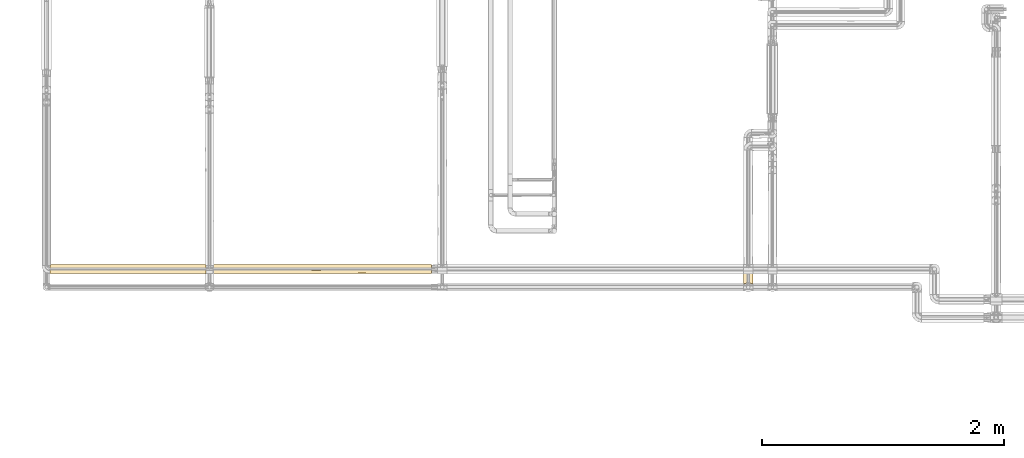
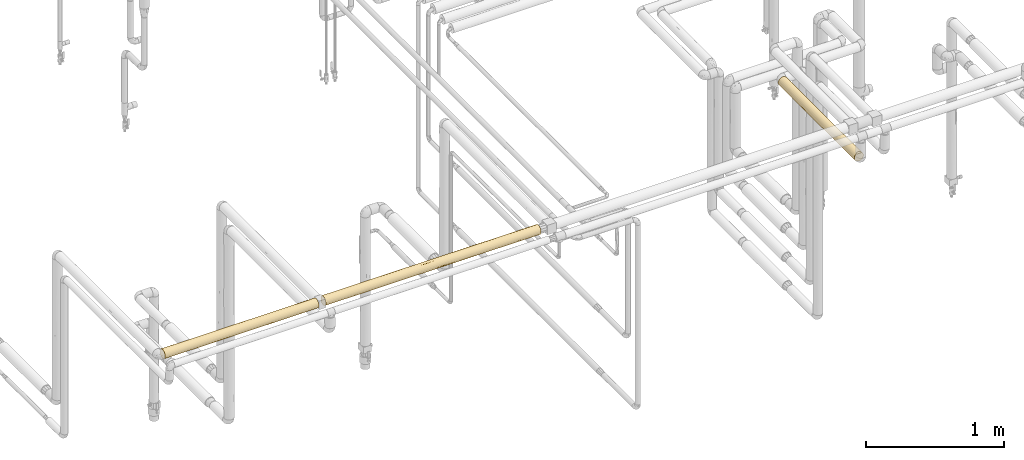
# One storey, part 22 of 827: 3 coverings.
"""IFC2X3 building model written with IfcOpenShell, lengths in millimetres."""

from ifc_helpers import new_model, entity, si_unit, converted_unit, derived_unit, direction, frame, origin, place, context, subcontext, project, spatial, faceted_brep, element, save


model = new_model("IFC2X3")

# Units and contexts
model_context = context("Model", 3, precision=0.01, world=origin(), true_north=direction((6.12303176911189e-17, 1.0)))
body_context = subcontext(model_context, "Body", "Model", "MODEL_VIEW")
ifc_project = project(units=[si_unit("LENGTHUNIT", "METRE", prefix="MILLI"), si_unit("AREAUNIT", "SQUARE_METRE"), si_unit("VOLUMEUNIT", "CUBIC_METRE"), converted_unit("PLANEANGLEUNIT", "DEGREE", entity("IfcRatioMeasure", 0.0174532925199433), si_unit("PLANEANGLEUNIT", "RADIAN"), dimensions=[0, 0, 0, 0, 0, 0, 0]), si_unit("MASSUNIT", "GRAM", prefix="KILO"), derived_unit("MASSDENSITYUNIT", [(si_unit("MASSUNIT", "GRAM", prefix="KILO"), 1), (si_unit("LENGTHUNIT", "METRE"), -3)]), derived_unit("MOMENTOFINERTIAUNIT", [(si_unit("LENGTHUNIT", "METRE"), 4)]), si_unit("TIMEUNIT", "SECOND"), si_unit("FREQUENCYUNIT", "HERTZ"), si_unit("THERMODYNAMICTEMPERATUREUNIT", "DEGREE_CELSIUS"), derived_unit("THERMALTRANSMITTANCEUNIT", [(si_unit("MASSUNIT", "GRAM", prefix="KILO"), 1), (si_unit("THERMODYNAMICTEMPERATUREUNIT", "KELVIN"), -1), (si_unit("TIMEUNIT", "SECOND"), -3)]), derived_unit("VOLUMETRICFLOWRATEUNIT", [(si_unit("LENGTHUNIT", "METRE"), 3), (si_unit("TIMEUNIT", "SECOND"), -1)]), derived_unit("MASSFLOWRATEUNIT", [(si_unit("MASSUNIT", "GRAM", prefix="KILO"), 1), (si_unit("TIMEUNIT", "SECOND"), -1)]), derived_unit("ROTATIONALFREQUENCYUNIT", [(si_unit("TIMEUNIT", "SECOND"), -1)]), si_unit("ELECTRICCURRENTUNIT", "AMPERE"), si_unit("ELECTRICVOLTAGEUNIT", "VOLT"), si_unit("POWERUNIT", "WATT"), si_unit("FORCEUNIT", "NEWTON", prefix="KILO"), si_unit("ILLUMINANCEUNIT", "LUX"), si_unit("LUMINOUSFLUXUNIT", "LUMEN"), si_unit("LUMINOUSINTENSITYUNIT", "CANDELA"), derived_unit("USERDEFINED", [(si_unit("MASSUNIT", "GRAM", prefix="KILO"), -1), (si_unit("LENGTHUNIT", "METRE"), -2), (si_unit("TIMEUNIT", "SECOND"), 3), (si_unit("LUMINOUSFLUXUNIT", "LUMEN"), 1)]), derived_unit("LINEARVELOCITYUNIT", [(si_unit("LENGTHUNIT", "METRE"), 1), (si_unit("TIMEUNIT", "SECOND"), -1)]), si_unit("PRESSUREUNIT", "PASCAL"), derived_unit("USERDEFINED", [(si_unit("LENGTHUNIT", "METRE"), -2), (si_unit("MASSUNIT", "GRAM", prefix="KILO"), 1), (si_unit("TIMEUNIT", "SECOND"), -2)]), derived_unit("LINEARFORCEUNIT", [(si_unit("MASSUNIT", "GRAM", prefix="KILO"), 1), (si_unit("LENGTHUNIT", "METRE"), 1), (si_unit("TIMEUNIT", "SECOND"), -2), (si_unit("LENGTHUNIT", "METRE"), -1)]), derived_unit("PLANARFORCEUNIT", [(si_unit("MASSUNIT", "GRAM", prefix="KILO"), 1), (si_unit("LENGTHUNIT", "METRE"), 1), (si_unit("TIMEUNIT", "SECOND"), -2), (si_unit("LENGTHUNIT", "METRE"), -2)])], contexts=[model_context])

# Site, building, storey
site_placement = place(None, origin())
site = spatial("IfcSite", under=ifc_project, at=site_placement, CompositionType="ELEMENT")
building_placement = place(site_placement, origin())
building = spatial("IfcBuilding", under=site, at=building_placement, CompositionType="ELEMENT")
storey_placement = place(building_placement, frame((0.0, 0.0, 28200.0)))
storey = spatial("IfcBuildingStorey", under=building, at=storey_placement, Name="08", CompositionType="ELEMENT", Elevation=28200.0)

# Coverings
covering_1_placement = place(storey_placement, frame((11959.41, 9702.8, 2810.01)))
element("IfcCovering", 1, at=covering_1_placement, inside=storey, Name=":ADSK_", ObjectType=":ADSK_", PredefinedType="INSULATION", context=body_context, shape_type="Brep", body=[
    faceted_brep([(1.6, 6.74, 20.8), (1.6, 2.9, 30.06), (1.6, 1.6, 40.0), (1.6, 2.9, 49.93), (1.6, 6.74, 59.2), (1.6, 12.84, 67.15), (1.6, 20.8, 73.25), (1.6, 30.06, 77.09), (1.6, 40.0, 78.4), (1.6, 48.2, 77.51), (1.6, 56.01, 74.9), (1.6, 63.08, 70.68), (1.6, 69.1, 65.05), (1.6, 69.1, 14.94), (1.6, 63.08, 9.31), (1.6, 56.01, 5.09), (1.6, 48.2, 2.48), (1.6, 40.0, 1.6), (1.6, 30.06, 2.9), (1.6, 20.8, 6.74), (1.6, 12.84, 12.84), (1290.39, 1.6, 40.0), (1290.39, 2.9, 30.06), (1290.39, 6.74, 20.8), (1290.39, 12.84, 12.84), (1290.39, 20.8, 6.74), (1290.39, 30.06, 2.9), (1290.39, 40.0, 1.6), (1290.39, 48.16, 2.47), (1290.39, 55.94, 5.06), (1290.39, 62.99, 9.24), (1290.39, 69.0, 14.82), (1290.39, 69.0, 65.17), (1290.39, 62.99, 70.75), (1290.39, 55.94, 74.93), (1290.39, 48.16, 77.52), (1290.39, 40.0, 78.4), (1290.39, 30.06, 77.09), (1290.39, 20.8, 73.25), (1290.39, 12.84, 67.15), (1290.39, 6.74, 59.2), (1290.39, 2.9, 49.93), (1281.6, 77.78, 33.17), (1283.41, 75.97, 26.56), (970.5, 77.48, 31.67), (1072.02, 59.58, 6.96), (1013.88, 52.12, 3.56), (1013.87, 66.14, 11.87), (256.38, 52.17, 3.58), (213.25, 40.0, 1.6), (186.53, 59.66, 7.01), (1286.38, 73.01, 20.38), (940.16, 74.55, 23.24), (1093.87, 71.05, 17.4), (877.22, 70.5, 16.67), (1064.62, 78.4, 40.0), (876.39, 78.4, 40.0), (828.29, 59.58, 6.96), (647.31, 76.53, 28.17), (353.03, 74.59, 23.33), (335.45, 77.52, 31.84), (227.27, 78.4, 40.0), (443.64, 78.4, 40.0), (5.57, 73.07, 20.48), (387.82, 70.53, 16.71), (506.99, 66.03, 11.77), (406.4, 59.66, 7.01), (256.39, 66.24, 11.96), (605.06, 50.39, 3.03), (857.64, 40.0, 1.6), (650.71, 40.0, 1.6), (641.27, 40.0, 1.6), (434.34, 40.0, 1.6), (424.9, 40.0, 1.6), (8.5, 76.0, 26.63), (10.29, 77.79, 33.21), (617.64, 60.96, 7.83), (745.51, 65.81, 11.57), (646.28, 70.86, 17.15), (1074.02, 40.0, 1.6), (1280.99, 78.4, 40.0), (660.01, 78.4, 40.0), (10.9, 78.4, 40.0), (802.88, 52.96, 3.85), (867.09, 40.0, 1.6), (217.97, 40.0, 1.6), (1031.19, 16.62, 9.53), (966.12, 9.53, 16.62), (326.15, 32.88, 2.26), (650.71, 31.56, 2.53), (372.63, 25.3, 4.52), (919.35, 25.3, 4.52), (970.55, 32.82, 2.27), (1074.01, 1.6, 40.0), (213.25, 1.6, 40.0), (682.58, 23.7, 5.22), (330.19, 2.29, 32.72), (1045.33, 4.52, 25.3), (570.15, 6.82, 20.65), (760.67, 4.52, 25.3), (516.3, 3.48, 28.12), (965.83, 2.29, 32.71), (372.63, 9.53, 16.62), (271.94, 4.52, 25.3), (271.94, 16.62, 9.53), (645.99, 16.62, 9.53), (577.96, 11.3, 14.48), (773.6, 7.9, 18.91), (790.0, 12.41, 13.28), (728.74, 2.22, 33.12), (867.09, 1.6, 40.0), (857.64, 1.6, 40.0), (641.27, 1.6, 40.0), (434.34, 1.6, 40.0), (424.9, 1.6, 40.0), (650.71, 1.6, 40.0), (217.97, 1.6, 40.0), (1031.19, 9.53, 63.37), (966.12, 16.62, 70.46), (326.15, 2.26, 47.11), (650.71, 2.53, 48.43), (372.63, 4.52, 54.69), (919.35, 4.52, 54.69), (970.55, 2.27, 47.17), (1074.02, 40.0, 78.4), (213.25, 40.0, 78.4), (682.58, 5.22, 56.29), (330.19, 32.72, 77.7), (1045.33, 25.3, 75.47), (570.15, 20.65, 73.17), (760.67, 25.3, 75.47), (516.3, 28.12, 76.51), (965.83, 32.71, 77.7), (372.63, 16.62, 70.46), (271.94, 25.3, 75.47), (271.94, 9.53, 63.37), (645.99, 9.53, 63.37), (577.96, 14.48, 68.69), (773.6, 18.91, 72.09), (790.0, 13.28, 67.58), (728.74, 33.12, 77.77), (857.65, 40.0, 78.4), (641.27, 40.0, 78.4), (424.9, 40.0, 78.4), (1012.73, 52.12, 76.43), (941.13, 74.55, 56.75), (860.76, 70.98, 62.67), (1075.52, 71.22, 62.34), (825.43, 59.58, 73.03), (1075.89, 59.58, 73.03), (748.41, 65.91, 68.33), (508.18, 66.05, 68.2), (615.48, 60.95, 72.17), (1286.38, 73.01, 59.61), (185.74, 59.66, 72.98), (255.85, 66.24, 68.03), (1012.72, 66.14, 68.12), (8.5, 76.0, 53.36), (5.57, 73.07, 59.51), (351.5, 74.59, 56.66), (255.84, 52.17, 76.41), (1283.41, 75.97, 53.43), (1281.6, 77.78, 46.82), (970.5, 77.48, 48.32), (404.94, 59.66, 72.98), (604.97, 50.41, 76.96), (387.57, 70.53, 63.28), (821.82, 47.82, 77.59), (645.69, 70.94, 62.73), (10.29, 77.79, 46.78), (335.45, 77.52, 48.15), (647.02, 76.51, 51.88)], [[[0, 1, 2, 3, 4, 5, 6, 7, 8, 9, 10, 11, 12, 13, 14, 15, 16, 17, 18, 19, 20]], [[21, 22, 23, 24, 25, 26, 27, 28, 29, 30, 31, 32, 33, 34, 35, 36, 37, 38, 39, 40, 41]], [[42, 43, 44]], [[45, 29, 46]], [[47, 31, 30]], [[48, 49, 16]], [[15, 14, 50]], [[43, 51, 52]], [[53, 47, 54]], [[55, 44, 56]], [[45, 57, 47]], [[58, 59, 60]], [[61, 62, 60]], [[63, 59, 64]], [[65, 66, 67]], [[68, 69, 70, 71, 72, 73]], [[74, 59, 63]], [[46, 29, 28]], [[61, 60, 75]], [[53, 51, 31]], [[48, 16, 15]], [[48, 68, 73]], [[57, 76, 77]], [[15, 50, 48]], [[50, 67, 66]], [[57, 45, 46]], [[78, 52, 54]], [[28, 79, 46]], [[55, 80, 42]], [[58, 78, 59]], [[76, 66, 65]], [[52, 78, 58]], [[14, 13, 67]], [[58, 62, 81, 56]], [[74, 75, 60]], [[75, 82, 61]], [[58, 60, 62]], [[60, 59, 74]], [[56, 44, 58]], [[64, 13, 63]], [[64, 78, 65]], [[68, 48, 66]], [[49, 17, 16]], [[76, 68, 66]], [[83, 57, 46]], [[44, 43, 52]], [[42, 44, 55]], [[58, 44, 52]], [[67, 50, 14]], [[48, 50, 66]], [[64, 65, 67]], [[65, 78, 77]], [[54, 77, 78]], [[47, 57, 77]], [[64, 67, 13]], [[78, 64, 59]], [[77, 76, 65]], [[76, 57, 83]], [[47, 30, 45]], [[29, 45, 30]], [[53, 52, 51]], [[77, 54, 47]], [[47, 53, 31]], [[52, 53, 54]], [[79, 28, 27]], [[46, 79, 84, 69]], [[48, 73, 85, 49]], [[69, 83, 46]], [[76, 83, 68]], [[69, 68, 83]], [[86, 24, 87]], [[88, 89, 90]], [[18, 85, 88]], [[18, 90, 19]], [[26, 25, 91]], [[92, 26, 91]], [[22, 21, 93]], [[94, 2, 1]], [[72, 89, 88]], [[90, 89, 95]], [[96, 94, 1]], [[23, 97, 87]], [[98, 99, 100]], [[97, 101, 99]], [[26, 79, 27]], [[18, 17, 49, 85]], [[88, 85, 73, 72]], [[102, 103, 0]], [[104, 20, 19]], [[23, 22, 97]], [[23, 87, 24]], [[90, 104, 19]], [[102, 0, 20]], [[1, 0, 103]], [[104, 105, 106]], [[107, 106, 108]], [[109, 100, 99]], [[24, 86, 25]], [[99, 101, 109]], [[86, 105, 91]], [[105, 104, 90]], [[98, 100, 103]], [[96, 103, 100]], [[102, 20, 104]], [[86, 87, 108]], [[91, 25, 86]], [[93, 101, 22]], [[97, 99, 107]], [[101, 93, 110, 111]], [[101, 111, 109]], [[22, 101, 97]], [[100, 112, 113, 114]], [[114, 96, 100]], [[109, 112, 100]], [[98, 103, 102]], [[106, 98, 102]], [[107, 108, 87]], [[109, 111, 115, 112]], [[104, 106, 102]], [[108, 106, 105]], [[86, 108, 105]], [[97, 107, 87]], [[99, 98, 107]], [[106, 107, 98]], [[89, 72, 71, 70, 69, 84]], [[18, 88, 90]], [[92, 89, 84]], [[89, 91, 95]], [[1, 103, 96]], [[96, 114, 116, 94]], [[26, 92, 79]], [[84, 79, 92]], [[89, 92, 91]], [[91, 105, 95]], [[90, 95, 105]], [[117, 39, 118]], [[119, 120, 121]], [[3, 116, 119]], [[3, 121, 4]], [[41, 40, 122]], [[123, 41, 122]], [[37, 36, 124]], [[125, 8, 7]], [[113, 120, 119]], [[121, 120, 126]], [[127, 125, 7]], [[38, 128, 118]], [[129, 130, 131]], [[128, 132, 130]], [[41, 93, 21]], [[3, 2, 94, 116]], [[119, 116, 114, 113]], [[133, 134, 6]], [[135, 5, 4]], [[38, 37, 128]], [[38, 118, 39]], [[121, 135, 4]], [[133, 6, 5]], [[7, 6, 134]], [[135, 136, 137]], [[138, 137, 139]], [[140, 131, 130]], [[39, 117, 40]], [[130, 132, 140]], [[117, 136, 122]], [[129, 131, 134]], [[127, 134, 131]], [[136, 135, 121]], [[133, 5, 135]], [[117, 118, 139]], [[122, 40, 117]], [[124, 132, 37]], [[128, 130, 138]], [[132, 124, 141]], [[132, 141, 140]], [[37, 132, 128]], [[131, 142, 143]], [[143, 127, 131]], [[140, 142, 131]], [[129, 134, 133]], [[137, 129, 133]], [[138, 139, 118]], [[140, 141, 142]], [[135, 137, 133]], [[139, 137, 136]], [[117, 139, 136]], [[128, 138, 118]], [[130, 129, 138]], [[137, 138, 129]], [[120, 113, 112, 115, 111, 110]], [[3, 119, 121]], [[123, 120, 110]], [[120, 122, 126]], [[7, 134, 127]], [[127, 143, 125]], [[41, 123, 93]], [[110, 93, 123]], [[120, 123, 122]], [[122, 136, 126]], [[121, 126, 136]], [[144, 124, 35]], [[145, 146, 147]], [[148, 144, 149]], [[150, 151, 152]], [[147, 32, 153]], [[11, 154, 155]], [[33, 156, 149]], [[124, 36, 35]], [[157, 158, 159]], [[9, 125, 160]], [[161, 162, 163]], [[34, 144, 35]], [[164, 160, 165]], [[11, 10, 154]], [[155, 151, 166]], [[167, 148, 165]], [[150, 168, 151]], [[149, 34, 33]], [[169, 170, 61]], [[32, 156, 33]], [[170, 159, 171]], [[163, 162, 55]], [[141, 124, 167, 142]], [[164, 154, 160]], [[55, 56, 163]], [[169, 157, 170]], [[166, 12, 155]], [[145, 147, 153]], [[11, 155, 12]], [[171, 168, 145]], [[61, 82, 169]], [[145, 153, 161]], [[10, 9, 160]], [[171, 56, 81, 62]], [[170, 157, 159]], [[62, 61, 170]], [[159, 168, 171]], [[162, 80, 55]], [[171, 62, 170]], [[148, 167, 144]], [[165, 160, 143]], [[165, 143, 142]], [[152, 165, 148]], [[151, 155, 164]], [[166, 158, 12]], [[163, 171, 145]], [[125, 9, 8]], [[163, 145, 161]], [[160, 154, 10]], [[155, 154, 164]], [[152, 151, 164]], [[166, 168, 159]], [[148, 156, 150]], [[146, 156, 147]], [[168, 166, 151]], [[158, 166, 159]], [[165, 152, 164]], [[150, 152, 148]], [[148, 149, 156]], [[34, 149, 144]], [[146, 145, 168]], [[32, 147, 156]], [[168, 150, 146]], [[156, 146, 150]], [[167, 124, 144]], [[56, 171, 163]], [[125, 143, 160]], [[142, 167, 165]], [[12, 158, 157, 169, 82, 75, 74, 63, 13]], [[80, 162, 161, 153, 32, 31, 51, 43, 42]]]),
])
covering_2_placement = place(storey_placement, frame((13306.2, 9702.8, 2810.0)))
element("IfcCovering", 2, at=covering_2_placement, inside=storey, Name=":ADSK_", ObjectType=":ADSK_", PredefinedType="INSULATION", context=body_context, shape_type="Brep", body=[
    faceted_brep([(1805.73, 77.09, 30.15), (1805.72, 78.4, 40.09), (1805.72, 77.09, 50.02), (1805.72, 73.25, 59.29), (1805.72, 67.15, 67.24), (1805.72, 59.2, 73.34), (1805.72, 49.93, 77.18), (1805.72, 40.0, 78.49), (1805.72, 30.06, 77.18), (1805.72, 20.8, 73.34), (1805.72, 12.84, 67.24), (1805.72, 6.74, 59.29), (1805.72, 2.9, 50.02), (1805.72, 1.6, 40.09), (1805.73, 2.9, 30.15), (1805.73, 6.74, 20.89), (1805.73, 12.84, 12.93), (1805.73, 20.8, 6.83), (1805.73, 30.06, 2.99), (1805.73, 40.0, 1.69), (1805.73, 49.93, 2.99), (1805.73, 59.2, 6.83), (1805.73, 67.15, 12.93), (1805.73, 73.25, 20.89), (1.6, 69.0, 14.83), (1.6, 62.99, 9.24), (1.6, 55.94, 5.06), (1.6, 48.16, 2.47), (1.6, 40.0, 1.6), (1.6, 30.06, 2.9), (1.6, 20.8, 6.74), (1.6, 12.84, 12.84), (1.6, 6.74, 20.8), (1.6, 2.9, 30.06), (1.6, 1.6, 40.0), (1.6, 2.9, 49.93), (1.6, 6.74, 59.2), (1.6, 12.84, 67.15), (1.59, 20.8, 73.25), (1.59, 30.06, 77.09), (1.59, 40.0, 78.4), (1.59, 48.16, 77.52), (1.59, 55.94, 74.93), (1.59, 62.99, 70.75), (1.6, 68.99, 65.17), (563.24, 2.22, 33.14), (888.06, 3.65, 27.66), (867.09, 1.6, 40.04), (1221.95, 2.49, 31.8), (1372.98, 1.6, 40.06), (1120.03, 1.6, 40.05), (246.65, 4.52, 25.31), (537.94, 8.17, 18.54), (325.87, 9.53, 16.64), (338.92, 25.3, 4.54), (434.34, 1.6, 40.02), (326.16, 2.29, 32.73), (760.38, 8.08, 18.68), (1068.16, 9.53, 16.67), (1610.33, 3.95, 26.83), (1481.17, 2.3, 32.75), (1300.86, 27.8, 3.65), (1120.04, 40.0, 1.65), (1372.98, 40.0, 1.66), (217.97, 1.6, 40.01), (1523.86, 9.53, 16.7), (1481.17, 32.89, 2.33), (1523.51, 25.3, 4.6), (1625.5, 16.62, 9.61), (1589.35, 1.6, 40.08), (855.92, 14.59, 11.25), (434.34, 40.0, 1.62), (650.72, 40.0, 1.63), (326.16, 32.96, 2.26), (217.97, 40.0, 1.61), (260.79, 16.62, 9.54), (564.39, 16.62, 9.56), (1394.27, 16.62, 9.6), (954.77, 20.22, 7.13), (1070.32, 26.22, 4.21), (1222.54, 21.47, 6.42), (1395.41, 4.52, 25.37), (1296.01, 8.3, 18.38), (867.09, 40.0, 1.64), (993.56, 33.41, 2.21), (703.19, 26.95, 3.92), (1122.99, 15.99, 10.08), (1589.35, 40.0, 1.68), (1145.88, 5.19, 23.84), (531.31, 4.52, 25.33), (650.72, 1.6, 40.03), (746.77, 19.54, 7.53), (217.92, 59.58, 6.97), (485.55, 59.58, 6.99), (286.99, 52.12, 3.57), (1481.17, 47.04, 2.32), (5.61, 73.01, 20.38), (386.76, 74.54, 23.25), (353.42, 70.79, 17.07), (804.69, 58.1, 6.17), (851.91, 48.29, 2.55), (614.01, 49.7, 2.87), (1553.14, 63.37, 9.61), (1229.19, 63.37, 9.59), (1523.86, 70.46, 16.7), (1462.87, 54.69, 4.59), (720.35, 70.83, 17.14), (731.04, 64.93, 10.83), (518.78, 67.85, 13.58), (287.0, 66.14, 11.89), (1610.33, 76.04, 26.83), (1481.17, 77.69, 32.75), (335.56, 77.49, 31.72), (688.56, 76.94, 29.55), (1395.41, 75.47, 25.37), (1203.41, 71.11, 17.55), (227.37, 78.4, 40.01), (10.39, 77.78, 33.17), (1589.35, 78.4, 40.08), (1214.91, 57.04, 5.65), (1282.64, 50.42, 3.1), (8.57, 75.97, 26.56), (1065.75, 52.05, 3.59), (1245.67, 77.43, 31.49), (1041.6, 76.24, 27.37), (966.77, 67.04, 12.78), (959.59, 72.55, 19.67), (443.74, 78.4, 40.02), (583.5, 73.67, 21.56), (11.0, 78.4, 40.0), (660.12, 78.4, 40.03), (876.49, 78.4, 40.04), (1372.98, 78.4, 40.06), (780.29, 74.54, 23.26), (1018.47, 60.7, 7.71), (1124.73, 78.4, 40.05), (286.99, 66.14, 68.13), (353.44, 70.78, 62.96), (434.34, 40.0, 78.42), (286.98, 52.12, 76.45), (217.97, 40.0, 78.41), (217.9, 59.58, 73.04), (518.82, 67.84, 66.46), (10.38, 77.78, 46.82), (335.56, 77.49, 48.31), (1523.86, 70.46, 63.45), (8.57, 75.97, 53.43), (5.61, 73.01, 59.61), (386.8, 74.54, 56.78), (1462.89, 54.69, 75.55), (1610.33, 76.04, 53.32), (1481.17, 77.69, 47.39), (1553.13, 63.37, 70.54), (688.57, 76.94, 50.51), (1041.61, 76.24, 52.72), (1282.65, 50.42, 77.02), (1120.03, 40.0, 78.45), (1156.6, 40.0, 78.45), (1372.97, 40.0, 78.46), (613.94, 49.7, 77.18), (851.87, 48.29, 77.53), (804.66, 58.1, 73.9), (1229.25, 63.37, 70.52), (1203.4, 71.11, 62.56), (1245.67, 77.43, 48.63), (1395.41, 75.47, 54.76), (731.13, 64.93, 69.24), (1018.44, 60.7, 72.39), (1481.16, 47.04, 77.82), (485.56, 59.58, 73.05), (1214.91, 57.04, 74.46), (1065.75, 52.05, 76.51), (1589.35, 40.0, 78.48), (720.42, 70.83, 62.92), (780.3, 74.54, 56.81), (583.53, 73.66, 58.49), (966.84, 67.04, 67.31), (959.61, 72.54, 60.42), (650.71, 40.0, 78.43), (687.29, 40.0, 78.43), (867.08, 40.0, 78.44), (940.23, 40.0, 78.44), (1481.45, 16.62, 70.53), (1546.53, 9.53, 63.45), (1285.18, 3.08, 50.64), (411.91, 25.3, 75.49), (585.37, 31.73, 77.53), (326.15, 32.67, 77.71), (260.79, 16.62, 70.47), (246.65, 4.52, 54.7), (325.87, 9.53, 63.39), (196.99, 26.75, 76.05), (1560.67, 25.3, 75.55), (1481.16, 32.71, 77.77), (1276.01, 25.3, 75.54), (1468.41, 4.52, 54.76), (919.26, 27.62, 76.39), (326.16, 2.29, 47.29), (531.31, 4.52, 54.72), (563.24, 2.22, 46.9), (793.02, 3.5, 51.99), (739.16, 16.62, 70.5), (755.14, 8.65, 62.21), (1038.13, 14.92, 69.13), (1481.17, 2.25, 47.11), (1244.08, 33.12, 77.84), (1215.07, 5.63, 57.18), (1067.9, 3.56, 52.17), (1067.34, 21.67, 73.8), (1264.47, 14.89, 69.11), (1242.93, 9.53, 63.43), (571.52, 12.12, 66.43), (556.8, 7.77, 60.91), (661.44, 23.78, 74.84), (499.97, 18.21, 71.64), (1003.92, 7.98, 61.25)], [[[0, 1, 2, 3, 4, 5, 6, 7, 8, 9, 10, 11, 12, 13, 14, 15, 16, 17, 18, 19, 20, 21, 22, 23]], [[24, 25, 26, 27, 28, 29, 30, 31, 32, 33, 34, 35, 36, 37, 38, 39, 40, 41, 42, 43, 44]], [[45, 46, 47]], [[48, 49, 50]], [[33, 32, 51]], [[52, 51, 53]], [[30, 29, 54]], [[45, 55, 56]], [[46, 57, 58]], [[59, 14, 60]], [[61, 62, 63]], [[53, 32, 31]], [[64, 56, 55]], [[65, 15, 59]], [[65, 16, 15]], [[66, 18, 67]], [[63, 66, 61]], [[17, 16, 68]], [[60, 69, 49]], [[57, 70, 58]], [[71, 72, 73, 74]], [[75, 53, 31]], [[17, 68, 67]], [[75, 76, 53]], [[68, 65, 77]], [[17, 67, 18]], [[78, 79, 80]], [[60, 48, 81]], [[14, 13, 69]], [[33, 64, 34]], [[82, 77, 65]], [[29, 74, 73]], [[83, 84, 85]], [[31, 30, 75]], [[52, 76, 57]], [[80, 86, 78]], [[18, 66, 87]], [[86, 58, 70]], [[85, 76, 54]], [[81, 88, 82]], [[30, 54, 75]], [[76, 75, 54]], [[67, 68, 77]], [[85, 54, 73]], [[73, 72, 85]], [[53, 51, 32]], [[56, 33, 51]], [[89, 45, 56]], [[33, 56, 64]], [[89, 56, 51]], [[46, 45, 89]], [[45, 47, 90, 55]], [[57, 46, 89]], [[88, 81, 48]], [[87, 66, 63]], [[87, 19, 18]], [[29, 28, 74]], [[84, 83, 62]], [[61, 66, 67]], [[80, 67, 77]], [[61, 79, 84]], [[61, 84, 62]], [[85, 84, 79]], [[49, 48, 60]], [[69, 60, 14]], [[60, 81, 59]], [[46, 50, 47]], [[50, 46, 48]], [[88, 46, 58]], [[46, 88, 48]], [[82, 88, 58]], [[82, 58, 86]], [[81, 82, 65]], [[65, 59, 81]], [[15, 14, 59]], [[51, 52, 89]], [[29, 73, 54]], [[52, 57, 89]], [[70, 57, 76]], [[70, 91, 78]], [[86, 77, 82]], [[78, 86, 70]], [[80, 79, 61]], [[67, 80, 61]], [[77, 86, 80]], [[91, 70, 76]], [[85, 79, 78]], [[76, 85, 91]], [[85, 78, 91]], [[65, 68, 16]], [[72, 83, 85]], [[76, 52, 53]], [[92, 93, 94]], [[63, 95, 87]], [[96, 97, 98]], [[99, 100, 101]], [[102, 103, 104]], [[21, 20, 105]], [[94, 74, 27]], [[92, 26, 25]], [[106, 107, 108]], [[25, 109, 92]], [[0, 110, 111]], [[112, 113, 97]], [[102, 104, 22]], [[114, 104, 115]], [[116, 112, 117]], [[104, 23, 22]], [[118, 1, 0]], [[24, 109, 25]], [[119, 105, 120]], [[97, 96, 121]], [[100, 99, 122]], [[114, 123, 111]], [[26, 94, 27]], [[111, 110, 114]], [[124, 114, 115]], [[125, 106, 126]], [[104, 114, 110]], [[116, 127, 112]], [[121, 117, 112]], [[94, 101, 71]], [[98, 24, 96]], [[128, 108, 98]], [[101, 94, 93]], [[27, 74, 28]], [[20, 87, 95]], [[62, 122, 120]], [[117, 129, 116]], [[113, 127, 130, 131]], [[112, 97, 121]], [[123, 132, 111]], [[113, 133, 128]], [[22, 21, 102]], [[115, 104, 103]], [[105, 95, 120]], [[101, 93, 99]], [[100, 72, 101]], [[125, 115, 103]], [[71, 74, 94]], [[133, 124, 126]], [[126, 115, 125]], [[131, 124, 113]], [[21, 105, 102]], [[103, 102, 105]], [[125, 107, 106]], [[119, 134, 103]], [[134, 125, 103]], [[125, 134, 107]], [[0, 111, 118]], [[132, 118, 111]], [[124, 131, 135]], [[123, 114, 124]], [[124, 135, 123]], [[132, 123, 135]], [[0, 23, 110]], [[104, 110, 23]], [[20, 19, 87]], [[62, 120, 63]], [[20, 95, 105]], [[62, 83, 72, 100]], [[120, 95, 63]], [[119, 120, 122]], [[134, 122, 99]], [[105, 119, 103]], [[122, 134, 119]], [[134, 99, 107]], [[133, 126, 106]], [[124, 115, 126]], [[99, 93, 107]], [[108, 93, 109]], [[93, 108, 107]], [[98, 108, 109]], [[98, 109, 24]], [[98, 97, 128]], [[128, 133, 106]], [[124, 133, 113]], [[128, 106, 108]], [[113, 128, 97]], [[93, 92, 109]], [[26, 92, 94]], [[127, 113, 112]], [[62, 100, 122]], [[72, 71, 101]], [[44, 136, 137]], [[138, 139, 140]], [[139, 141, 42]], [[137, 136, 142]], [[141, 136, 43]], [[44, 43, 136]], [[143, 144, 116]], [[3, 145, 4]], [[146, 147, 148]], [[149, 6, 5]], [[150, 2, 151]], [[152, 5, 4]], [[153, 154, 131]], [[155, 156, 157, 158]], [[132, 151, 118]], [[116, 129, 143]], [[159, 160, 161]], [[162, 145, 163]], [[130, 127, 153, 131]], [[164, 154, 165]], [[166, 161, 167]], [[143, 146, 144]], [[139, 42, 41]], [[2, 118, 151]], [[3, 150, 145]], [[168, 6, 149]], [[169, 139, 159]], [[136, 141, 169]], [[145, 152, 4]], [[127, 144, 153]], [[169, 166, 142]], [[137, 147, 44]], [[139, 41, 140]], [[159, 139, 138]], [[155, 170, 171]], [[6, 172, 7]], [[144, 146, 148]], [[127, 116, 144]], [[144, 148, 153]], [[173, 174, 175]], [[176, 177, 173]], [[163, 145, 165]], [[152, 162, 149]], [[159, 161, 169]], [[158, 168, 155]], [[159, 138, 178]], [[159, 178, 160]], [[41, 40, 140]], [[154, 163, 165]], [[163, 177, 176]], [[164, 165, 151]], [[177, 174, 173]], [[162, 152, 145]], [[149, 5, 152]], [[167, 171, 170]], [[176, 162, 163]], [[166, 176, 173]], [[176, 166, 167]], [[2, 1, 118]], [[135, 164, 132]], [[151, 165, 150]], [[154, 135, 131]], [[132, 164, 151]], [[135, 154, 164]], [[145, 150, 165]], [[3, 2, 150]], [[6, 168, 172]], [[158, 172, 168]], [[160, 156, 171]], [[155, 168, 149]], [[170, 149, 162]], [[156, 155, 171]], [[149, 170, 155]], [[167, 170, 162]], [[176, 167, 162]], [[171, 167, 161]], [[163, 154, 177]], [[174, 154, 153]], [[142, 166, 173]], [[169, 161, 166]], [[175, 137, 142]], [[169, 142, 136]], [[175, 142, 173]], [[147, 137, 148]], [[154, 174, 177]], [[175, 153, 148]], [[153, 175, 174]], [[137, 175, 148]], [[42, 141, 43]], [[169, 141, 139]], [[160, 178, 179, 180, 181, 156]], [[161, 160, 171]], [[182, 183, 10]], [[50, 49, 184]], [[185, 186, 187]], [[38, 37, 188]], [[36, 189, 190]], [[191, 185, 187]], [[35, 34, 64]], [[12, 69, 13]], [[8, 7, 172]], [[140, 40, 39]], [[192, 193, 194]], [[195, 12, 11]], [[36, 35, 189]], [[196, 181, 180, 179]], [[189, 197, 198]], [[199, 200, 198]], [[9, 182, 10]], [[188, 37, 190]], [[39, 191, 187]], [[201, 202, 203]], [[204, 12, 195]], [[9, 8, 192]], [[182, 9, 192]], [[202, 198, 200]], [[194, 205, 196]], [[36, 190, 37]], [[183, 11, 10]], [[184, 206, 207]], [[194, 208, 209]], [[194, 193, 205]], [[183, 210, 195]], [[190, 189, 198]], [[211, 212, 202]], [[198, 197, 199]], [[201, 213, 214]], [[215, 203, 202]], [[49, 204, 184]], [[183, 182, 209]], [[195, 11, 183]], [[202, 201, 211]], [[191, 188, 185]], [[172, 193, 8]], [[182, 192, 194]], [[64, 197, 35]], [[193, 172, 158]], [[193, 158, 205]], [[8, 193, 192]], [[205, 158, 157, 156, 181]], [[196, 205, 181]], [[186, 138, 187]], [[208, 201, 203]], [[197, 64, 55]], [[197, 55, 199]], [[35, 197, 189]], [[200, 90, 47]], [[200, 47, 207]], [[199, 90, 200]], [[215, 207, 206]], [[200, 207, 215]], [[201, 214, 211]], [[199, 55, 90]], [[39, 187, 140]], [[138, 140, 187]], [[186, 179, 178, 138]], [[213, 196, 186]], [[213, 186, 185]], [[196, 179, 186]], [[214, 185, 188]], [[196, 213, 201]], [[185, 214, 213]], [[211, 188, 190]], [[188, 211, 214]], [[212, 190, 198]], [[39, 38, 191]], [[188, 191, 38]], [[12, 204, 69]], [[49, 69, 204]], [[207, 47, 50]], [[184, 204, 195]], [[206, 195, 210]], [[50, 184, 207]], [[195, 206, 184]], [[215, 206, 210]], [[215, 210, 203]], [[215, 202, 200]], [[209, 203, 210]], [[196, 208, 194]], [[190, 212, 211]], [[198, 202, 212]], [[183, 209, 210]], [[194, 209, 182]], [[201, 208, 196]], [[209, 208, 203]], [[44, 147, 146, 143, 129, 117, 121, 96, 24]]]),
])
covering_3_placement = place(storey_placement, frame((17688.53, 9620.3, 2611.73)))
element("IfcCovering", 3, at=covering_3_placement, inside=storey, Name=":ADSK_", ObjectType=":ADSK_", PredefinedType="INSULATION", context=body_context, shape_type="Brep", body=[
    faceted_brep([(20.8, 1106.83, 73.25), (30.06, 1106.83, 77.09), (40.0, 1106.83, 78.4), (48.2, 1106.83, 77.51), (56.01, 1106.83, 74.9), (63.08, 1106.83, 70.68), (69.1, 1106.83, 65.05), (69.1, 1106.83, 14.94), (63.08, 1106.83, 9.31), (56.01, 1106.83, 5.09), (48.2, 1106.83, 2.48), (40.0, 1106.83, 1.6), (30.06, 1106.83, 2.9), (20.8, 1106.83, 6.74), (12.84, 1106.83, 12.84), (6.74, 1106.83, 20.8), (2.9, 1106.83, 30.06), (1.6, 1106.83, 40.0), (2.9, 1106.83, 49.93), (6.74, 1106.83, 59.2), (12.84, 1106.83, 67.15), (65.05, 1.6, 69.1), (14.94, 1.6, 69.1), (9.31, 1.6, 63.08), (5.09, 1.6, 56.01), (2.48, 1.6, 48.2), (1.6, 1.6, 40.0), (2.9, 1.6, 30.06), (6.74, 1.6, 20.8), (12.84, 1.6, 12.84), (20.8, 1.6, 6.74), (30.06, 1.6, 2.9), (40.0, 1.6, 1.6), (49.93, 1.6, 2.9), (59.2, 1.6, 6.74), (67.15, 1.6, 12.84), (73.25, 1.6, 20.8), (77.09, 1.6, 30.06), (78.4, 1.6, 40.0), (77.51, 1.6, 48.2), (74.9, 1.6, 56.01), (70.68, 1.6, 63.08), (76.76, 543.75, 28.91), (74.4, 688.35, 22.95), (77.01, 790.94, 29.79), (78.4, 664.78, 40.0), (78.4, 434.34, 40.0), (75.47, 321.12, 25.3), (77.79, 1098.13, 33.21), (78.4, 881.15, 40.0), (54.69, 336.57, 4.52), (63.37, 263.04, 9.53), (76.0, 1099.93, 26.63), (71.09, 836.71, 17.47), (65.59, 783.01, 11.37), (40.0, 890.45, 1.6), (74.73, 904.34, 23.62), (70.46, 252.7, 16.62), (77.75, 326.15, 32.96), (73.07, 1102.85, 20.48), (40.0, 434.34, 1.6), (47.03, 326.15, 2.25), (40.0, 217.97, 1.6), (50.25, 782.27, 2.99), (50.6, 542.06, 3.09), (40.0, 674.08, 1.6), (59.66, 664.42, 7.01), (59.66, 901.6, 7.01), (65.42, 545.09, 11.22), (70.98, 551.13, 17.31), (78.4, 217.97, 40.0), (78.4, 1097.53, 40.0), (2.57, 819.86, 31.42), (16.62, 855.64, 9.53), (25.3, 843.37, 4.52), (27.98, 554.21, 3.52), (32.82, 782.27, 2.27), (32.82, 326.15, 2.27), (25.3, 265.05, 4.52), (16.62, 252.78, 9.53), (9.53, 334.86, 16.62), (10.59, 571.45, 15.3), (16.62, 554.21, 9.53), (2.27, 326.15, 32.8), (2.24, 570.0, 33.0), (4.52, 262.66, 25.3), (5.21, 883.62, 23.74), (4.52, 645.78, 25.3), (9.53, 808.04, 16.62), (1.6, 434.34, 40.0), (1.6, 217.97, 40.0), (1.6, 674.08, 40.0), (1.6, 770.58, 40.0), (1.6, 890.45, 40.0), (7.01, 444.0, 59.66), (2.96, 554.21, 50.13), (3.58, 268.54, 52.17), (4.52, 846.83, 54.69), (9.53, 778.61, 63.37), (2.28, 782.27, 47.19), (5.39, 638.13, 56.65), (11.37, 325.41, 65.59), (17.47, 271.71, 71.09), (7.01, 206.82, 59.66), (11.15, 557.87, 65.34), (16.62, 850.59, 70.46), (29.79, 317.48, 77.01), (22.95, 420.07, 74.4), (23.62, 204.08, 74.73), (25.3, 787.3, 75.47), (28.91, 564.67, 76.76), (40.0, 674.08, 78.4), (40.0, 443.64, 78.4), (33.21, 10.29, 77.79), (40.0, 227.27, 78.4), (26.63, 8.5, 76.0), (20.48, 5.57, 73.07), (32.96, 782.27, 77.75), (40.0, 890.45, 78.4), (17.31, 557.3, 70.98), (40.0, 775.23, 78.4), (40.0, 10.9, 78.4), (46.78, 10.29, 77.79), (60.69, 830.84, 72.34), (52.17, 736.22, 76.41), (59.51, 5.57, 73.07), (62.52, 268.39, 71.1), (76.41, 310.28, 52.17), (51.34, 526.24, 76.68), (53.36, 8.5, 76.0), (50.2, 317.48, 77.01), (76.0, 1099.93, 53.36), (73.07, 1102.85, 59.51), (74.6, 808.06, 56.63), (77.02, 822.52, 50.2), (62.68, 550.86, 70.98), (56.46, 199.81, 74.69), (66.34, 739.71, 67.94), (57.09, 413.38, 74.38), (68.54, 195.56, 65.68), (72.98, 214.96, 59.66), (73.79, 412.12, 58.22), (69.91, 403.73, 64.07), (70.69, 614.95, 63.07), (74.56, 609.11, 56.73), (77.79, 1098.13, 46.78), (71.09, 828.45, 62.53), (77.5, 549.56, 48.25)], [[[0, 1, 2, 3, 4, 5, 6, 7, 8, 9, 10, 11, 12, 13, 14, 15, 16, 17, 18, 19, 20]], [[21, 22, 23, 24, 25, 26, 27, 28, 29, 30, 31, 32, 33, 34, 35, 36, 37, 38, 39, 40, 41]], [[42, 43, 44]], [[45, 46, 42]], [[37, 36, 47]], [[48, 49, 44]], [[50, 51, 34]], [[44, 52, 48]], [[7, 53, 54]], [[55, 11, 10]], [[43, 56, 44]], [[51, 57, 35]], [[46, 58, 42]], [[53, 7, 59]], [[59, 52, 56]], [[60, 61, 62]], [[55, 10, 63]], [[64, 65, 63]], [[58, 37, 47]], [[66, 50, 64]], [[35, 34, 51]], [[9, 67, 63]], [[33, 50, 34]], [[9, 63, 10]], [[67, 9, 8]], [[33, 62, 61]], [[55, 63, 65]], [[36, 35, 57]], [[67, 54, 66]], [[54, 68, 66]], [[69, 68, 54]], [[50, 61, 64]], [[43, 42, 47]], [[37, 58, 70]], [[68, 50, 66]], [[69, 47, 57]], [[57, 51, 68]], [[47, 36, 57]], [[8, 7, 54]], [[63, 67, 66]], [[8, 54, 67]], [[69, 54, 53]], [[57, 68, 69]], [[50, 68, 51]], [[70, 58, 46]], [[70, 38, 37]], [[42, 58, 47]], [[43, 47, 69]], [[45, 42, 44]], [[69, 53, 43]], [[56, 43, 53]], [[59, 56, 53]], [[44, 56, 52]], [[33, 32, 62]], [[60, 65, 64]], [[33, 61, 50]], [[64, 61, 60]], [[66, 64, 63]], [[49, 48, 71]], [[49, 45, 44]], [[32, 31, 62]], [[12, 11, 55]], [[16, 72, 17]], [[73, 13, 74]], [[75, 76, 65]], [[77, 60, 62]], [[65, 76, 55]], [[31, 30, 78]], [[78, 30, 79]], [[73, 14, 13]], [[13, 12, 74]], [[28, 80, 29]], [[80, 81, 82]], [[83, 84, 85]], [[82, 81, 73]], [[65, 60, 75]], [[86, 87, 72]], [[87, 86, 88]], [[88, 15, 14]], [[82, 79, 80]], [[89, 83, 90]], [[84, 72, 87]], [[85, 80, 28]], [[78, 82, 75]], [[85, 28, 27]], [[81, 87, 88]], [[84, 87, 85]], [[30, 29, 79]], [[75, 60, 77]], [[55, 76, 12]], [[82, 74, 75]], [[90, 83, 27]], [[87, 80, 85]], [[80, 79, 29]], [[82, 78, 79]], [[82, 73, 74]], [[88, 14, 73]], [[75, 74, 76]], [[12, 76, 74]], [[27, 26, 90]], [[83, 89, 84]], [[27, 83, 85]], [[84, 89, 91, 92]], [[72, 84, 92]], [[72, 92, 93, 17]], [[86, 16, 15]], [[16, 86, 72]], [[88, 86, 15]], [[77, 31, 78]], [[31, 77, 62]], [[75, 77, 78]], [[87, 81, 80]], [[73, 81, 88]], [[94, 95, 96]], [[19, 18, 97]], [[19, 97, 98]], [[99, 93, 92, 91]], [[97, 100, 98]], [[101, 22, 102]], [[103, 24, 23]], [[25, 96, 90]], [[96, 25, 24]], [[98, 104, 105]], [[96, 95, 89]], [[95, 91, 89]], [[101, 94, 103]], [[94, 101, 104]], [[106, 107, 108]], [[20, 19, 98]], [[1, 0, 109]], [[0, 20, 105]], [[95, 99, 91]], [[96, 89, 90]], [[110, 107, 106]], [[111, 110, 112]], [[100, 104, 98]], [[113, 114, 106]], [[115, 113, 106]], [[116, 115, 108]], [[105, 109, 0]], [[116, 102, 22]], [[117, 110, 111]], [[117, 1, 109]], [[96, 24, 103]], [[26, 25, 90]], [[107, 110, 109]], [[1, 118, 2]], [[93, 99, 18]], [[94, 100, 95]], [[98, 105, 20]], [[109, 105, 119]], [[23, 22, 101]], [[96, 103, 94]], [[23, 101, 103]], [[119, 101, 102]], [[101, 119, 104]], [[105, 104, 119]], [[1, 117, 118]], [[117, 111, 120, 118]], [[110, 117, 109]], [[107, 109, 119]], [[112, 110, 106]], [[119, 102, 107]], [[108, 107, 102]], [[116, 108, 102]], [[106, 108, 115]], [[18, 17, 93]], [[100, 99, 95]], [[18, 99, 97]], [[114, 113, 121]], [[114, 112, 106]], [[100, 94, 104]], [[99, 100, 97]], [[121, 122, 114]], [[123, 4, 124]], [[125, 21, 126]], [[40, 39, 127]], [[120, 128, 124]], [[3, 124, 4]], [[122, 129, 130]], [[127, 39, 70]], [[114, 122, 130]], [[131, 132, 133]], [[134, 45, 49]], [[135, 123, 124]], [[128, 112, 130]], [[136, 125, 126]], [[5, 137, 6]], [[138, 126, 135]], [[139, 21, 41]], [[140, 141, 142]], [[143, 144, 133]], [[137, 5, 123]], [[143, 135, 142]], [[134, 49, 145]], [[135, 126, 142]], [[146, 143, 133]], [[138, 136, 126]], [[6, 146, 132]], [[133, 132, 146]], [[147, 46, 45]], [[134, 145, 131]], [[147, 134, 144]], [[49, 71, 145]], [[140, 142, 139]], [[46, 127, 70]], [[138, 128, 130]], [[40, 127, 140]], [[134, 147, 45]], [[147, 144, 141]], [[41, 140, 139]], [[41, 40, 140]], [[39, 38, 70]], [[46, 147, 127]], [[127, 147, 141]], [[142, 126, 139]], [[21, 139, 126]], [[124, 138, 135]], [[136, 130, 129]], [[130, 136, 138]], [[125, 136, 129]], [[138, 124, 128]], [[3, 120, 124]], [[127, 141, 140]], [[143, 141, 144]], [[130, 112, 114]], [[135, 143, 137]], [[4, 123, 5]], [[3, 2, 118, 120]], [[128, 120, 111, 112]], [[144, 134, 133]], [[131, 133, 134]], [[143, 146, 137]], [[141, 143, 142]], [[6, 137, 146]], [[135, 137, 123]], [[6, 132, 131, 145, 71, 48, 52, 59, 7]], [[129, 122, 121, 113, 115, 116, 22, 21, 125]]]),
])

save(model, "model.ifc")
